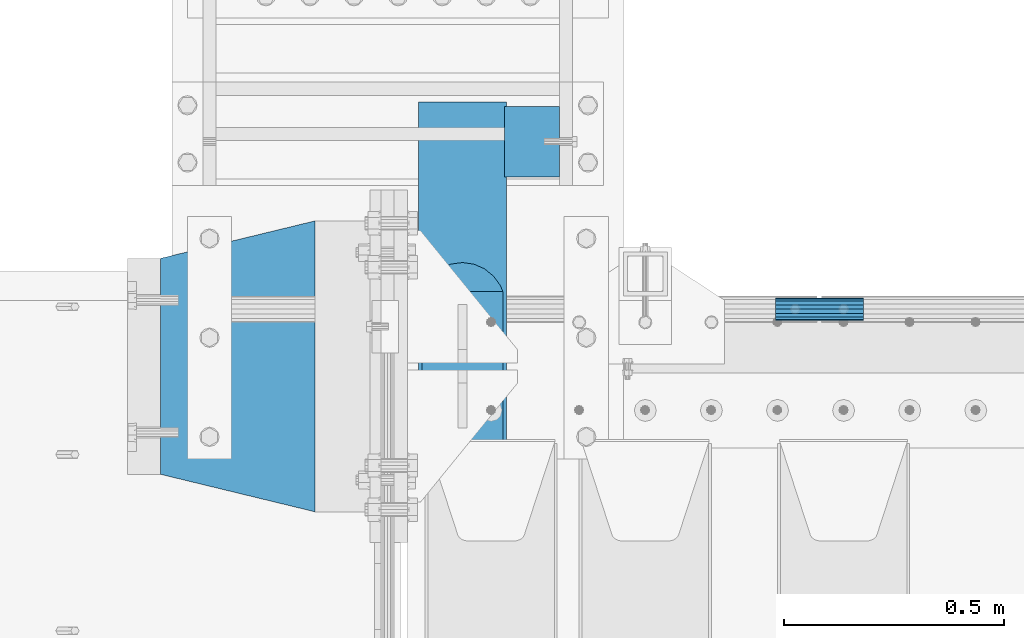
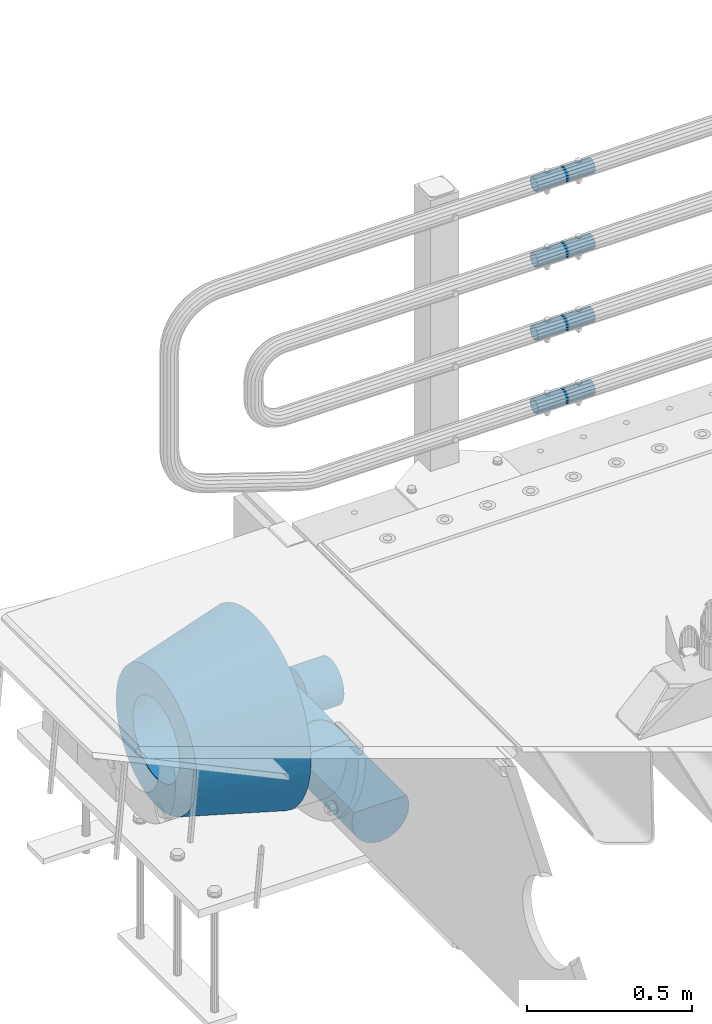
# One storey, part 121 of 208: 7 beams.
"""IFC2X3 building model written with IfcOpenShell, lengths in millimetres."""

import ifcopenshell
import ifcopenshell.guid

model = None  # the IFC model being written
_history = None  # IfcOwnerHistory: only IFC2X3 demands one
_inside = {}  # id of a spatial element -> (the spatial element, [elements in it])
_under = {}  # id of a project, library or spatial element -> (it, [spatial elements below it])
_declared = {}  # id of a project -> (the project, [libraries it declares])
_typed = {}  # id of a type object -> (the type object, [elements of that type])
_made_of = {}  # id of a material, layer set ... -> (it, [elements and type objects made of it])


def new_model(schema):
    """Start an empty IFC model of exactly this schema.

    Asked for "IFC4X3", IfcOpenShell would pick the latest addendum, in which some entities
    have other attributes; the version numbers below select the first issue.
    IFC2X3 requires an IfcOwnerHistory on every rooted entity: one is made here for all.
    """
    global model, _history
    if schema == "IFC4X3":
        model = ifcopenshell.file(schema_version=(4, 3, 0, 0))
    else:
        model = ifcopenshell.file(schema=schema)
    _inside.clear()
    _under.clear()
    _declared.clear()
    _typed.clear()
    _made_of.clear()
    _history = None
    if model.schema == "IFC2X3":
        org = make("IfcOrganization", Name="unknown")
        user = make(
            "IfcPersonAndOrganization",
            ThePerson=make("IfcPerson", FamilyName="unknown"),
            TheOrganization=org,
        )
        app = make(
            "IfcApplication",
            ApplicationDeveloper=org,
            Version="unknown",
            ApplicationFullName="unknown",
            ApplicationIdentifier="unknown",
        )
        _history = make(
            "IfcOwnerHistory",
            OwningUser=user,
            OwningApplication=app,
            ChangeAction="ADDED",
            CreationDate=0,
        )
    return model


def make(cls, **values):
    """One entity of the class cls with the attributes given. An attribute that is None is left unset."""
    return model.create_entity(
        cls, **{name: value for name, value in values.items() if value is not None}
    )


def rooted(cls, **values):
    """An entity with a GlobalId (a new one), such as an element, a storey or a relation."""
    return make(cls, GlobalId=ifcopenshell.guid.new(), OwnerHistory=_history, **values)


def si_unit(unit_type, name, prefix=None):
    """IfcSIUnit, for example si_unit("LENGTHUNIT", "METRE", prefix="MILLI")."""
    return make("IfcSIUnit", UnitType=unit_type, Prefix=prefix, Name=name)


def assignment(units):
    """IfcUnitAssignment: the units of a project."""
    return None if units is None else make("IfcUnitAssignment", Units=units)


def point(xyz):
    """IfcCartesianPoint."""
    return None if xyz is None else make("IfcCartesianPoint", Coordinates=xyz)


def direction(xyz):
    """IfcDirection."""
    return None if xyz is None else make("IfcDirection", DirectionRatios=xyz)


def frame(location, z_axis=None, x_axis=None):
    """IfcAxis2Placement3D, a coordinate frame: its origin and axes. An axis left out is left unset."""
    return make(
        "IfcAxis2Placement3D",
        Location=point(location),
        Axis=direction(z_axis),
        RefDirection=direction(x_axis),
    )


def origin_with_axes():
    """The frame at (0, 0, 0) with the z axis (0, 0, 1) and the x axis (1, 0, 0) written out."""
    return frame((0.0, 0.0, 0.0), z_axis=(0.0, 0.0, 1.0), x_axis=(1.0, 0.0, 0.0))


def place(relative_to, where):
    """IfcLocalPlacement: puts the frame where relative to a parent placement (None: the world)."""
    return make(
        "IfcLocalPlacement", PlacementRelTo=relative_to, RelativePlacement=where
    )


def context(
    kind, dimensions, precision=None, world=None, true_north=None, identifier=None
):
    """IfcGeometricRepresentationContext, for example the 3D "Model" context."""
    return make(
        "IfcGeometricRepresentationContext",
        ContextIdentifier=identifier,
        ContextType=kind,
        CoordinateSpaceDimension=dimensions,
        Precision=precision,
        WorldCoordinateSystem=world,
        TrueNorth=true_north,
    )


def subcontext(parent, identifier, kind, view, scale=None):
    """IfcGeometricRepresentationSubContext, for example "Body" below "Model"."""
    return make(
        "IfcGeometricRepresentationSubContext",
        ContextIdentifier=identifier,
        ContextType=kind,
        ParentContext=parent,
        TargetScale=scale,
        TargetView=view,
    )


def project(units=None, contexts=None):
    """IfcProject with its units and contexts."""
    return rooted(
        "IfcProject",
        Name="project",
        RepresentationContexts=contexts,
        UnitsInContext=assignment(units),
    )


def spatial(cls, under=None, at=None, **own):
    """A site, building, storey or space (cls), placed at a placement, below another one or the project."""
    s = rooted(cls, ObjectPlacement=at, **own)
    if under is not None:
        _under.setdefault(under.id(), (under, []))[1].append(s)
    return s


def faces_of(points, faces, orient=None, outer=None):
    """IfcFace entities. A face is a list of loops; a loop is a list of indices into points, from 0.

    orient and outer hold one flag for each loop. By default every Orientation is true, the
    first loop of a face is its IfcFaceOuterBound and the others are IfcFaceBound.
    """
    made = []
    for i, loops in enumerate(faces):
        bounds = []
        for j, loop in enumerate(loops):
            is_outer = j == 0 if outer is None else outer[i][j]
            bounds.append(
                make(
                    "IfcFaceOuterBound" if is_outer else "IfcFaceBound",
                    Bound=make("IfcPolyLoop", Polygon=[points[k] for k in loop]),
                    Orientation=True if orient is None else orient[i][j],
                )
            )
        made.append(make("IfcFace", Bounds=bounds))
    return made


def faceted_brep(points, faces, orient=None, outer=None, voids=None):
    """IfcFacetedBrep: a solid bounded by flat faces; with voids (closed shells), ...WithVoids."""
    shared = [point(p) for p in points]
    hull = make("IfcClosedShell", CfsFaces=faces_of(shared, faces, orient, outer))
    if voids is None:
        return make("IfcFacetedBrep", Outer=hull)
    return make(
        "IfcFacetedBrepWithVoids",
        Outer=hull,
        Voids=[
            make(cls, CfsFaces=faces_of(shared, fs, o, b)) for cls, fs, o, b in voids
        ],
    )


def shape(context_of_items, identifier, shape_type, items):
    """IfcShapeRepresentation: the items that make up one representation, for example the "Body"."""
    return make(
        "IfcShapeRepresentation",
        ContextOfItems=context_of_items,
        RepresentationIdentifier=identifier,
        RepresentationType=shape_type,
        Items=items,
    )


def material(Name=None, Category=None):
    """IfcMaterial."""
    return make("IfcMaterial", Name=Name, Category=Category)


def made_of(thing, what):
    """Note that an element or type object is made of a material, layer set ...; save() writes the relation."""
    if what is not None:
        _made_of.setdefault(what.id(), (what, []))[1].append(thing)
    return thing


def type_object(cls, material=None, **own):
    """A type object (cls), such as IfcWallType, which elements share."""
    return made_of(rooted(cls, **own), material)


def element(
    cls,
    number,
    at=None,
    inside=None,
    cuts=None,
    type_object=None,
    material=None,
    context=None,
    identifier="Body",
    shape_type=None,
    held_by="IfcProductDefinitionShape",
    body=None,
    shapes=None,
    **own,
):
    """One element of the class cls, such as IfcWall. Its Tag is "e" and its number.

    at: its placement. inside: the storey or other place that contains it. cuts: it is an
    opening in that element (IfcRelVoidsElement). A single representation is given by context,
    identifier, shape_type and body (its items); several are given by shapes. held_by: the class
    of the entity that holds the representations. save() writes the other relations.
    """
    e = rooted(cls, Tag="e%d" % number, ObjectPlacement=at, **own)
    if body is not None:
        shapes = [shape(context, identifier, shape_type, body)]
    if shapes is not None:
        e.Representation = make(held_by, Representations=shapes)
    if inside is not None:
        _inside.setdefault(inside.id(), (inside, []))[1].append(e)
    if cuts is not None:
        rooted(
            "IfcRelVoidsElement", RelatingBuildingElement=cuts, RelatedOpeningElement=e
        )
    if type_object is not None:
        _typed.setdefault(type_object.id(), (type_object, []))[1].append(e)
    return made_of(e, material)


def aggregate(whole, parts):
    """IfcRelAggregates: a whole, such as a stair, and the parts it consists of."""
    return rooted("IfcRelAggregates", RelatingObject=whole, RelatedObjects=parts)


def save(model, path):
    """Write the relations noted so far, then the file.

    IfcRelAggregates (storeys below a building ...), IfcRelContainedInSpatialStructure (elements
    in a storey), IfcRelDefinesByType, IfcRelAssociatesMaterial and IfcRelDeclares: one each for
    every whole, place, type object, material and project.
    """
    for whole, parts in _under.values():
        aggregate(whole, parts)
    for where, things in _inside.values():
        rooted(
            "IfcRelContainedInSpatialStructure",
            RelatedElements=things,
            RelatingStructure=where,
        )
    for kind, things in _typed.values():
        rooted("IfcRelDefinesByType", RelatedObjects=things, RelatingType=kind)
    for what, things in _made_of.values():
        rooted("IfcRelAssociatesMaterial", RelatedObjects=things, RelatingMaterial=what)
    for by, libraries in _declared.values():
        rooted("IfcRelDeclares", RelatingContext=by, RelatedDefinitions=libraries)
    model.write(path)


model = new_model("IFC2X3")

# Units and contexts
model_context = context("Model", 3, precision=1e-05, world=origin_with_axes())
body_context = subcontext(model_context, "Body", "Model", "MODEL_VIEW")
ifc_project = project(units=[si_unit("LENGTHUNIT", "METRE", prefix="MILLI"), si_unit("AREAUNIT", "SQUARE_METRE"), si_unit("VOLUMEUNIT", "CUBIC_METRE"), si_unit("MASSUNIT", "GRAM", prefix="KILO"), si_unit("TIMEUNIT", "SECOND"), si_unit("PLANEANGLEUNIT", "RADIAN"), si_unit("SOLIDANGLEUNIT", "STERADIAN"), si_unit("THERMODYNAMICTEMPERATUREUNIT", "DEGREE_CELSIUS"), si_unit("LUMINOUSINTENSITYUNIT", "LUMEN")], contexts=[model_context])

# Site, building, storey
site_placement = place(None, origin_with_axes())
site = spatial("IfcSite", under=ifc_project, at=site_placement, CompositionType="ELEMENT")
building_placement = place(site_placement, origin_with_axes())
building = spatial("IfcBuilding", under=site, at=building_placement, Name="Standard", CompositionType="ELEMENT")
storey_placement = place(building_placement, origin_with_axes())
storey = spatial("IfcBuildingStorey", under=building, at=storey_placement, Name="Undefined", CompositionType="ELEMENT", Elevation=0.0)

# Beams
ifc_material_1 = material(Name="STEEL/S355N")
beam_type_1 = type_object("IfcBeamType", Name="D200", PredefinedType="NOTDEFINED")
beam_1_placement = place(storey_placement, frame((-42315.0, 6600.0, -928.0), z_axis=(0.0, 0.0, 1.0), x_axis=(0.0, -1.0, 0.0)))
element("IfcBeam", 1, at=beam_1_placement, inside=storey, type_object=beam_type_1, material=ifc_material_1, ObjectType="D200", context=body_context, shape_type="Brep", body=[
    faceted_brep([(430.0, 91.573103126917, 38.0), (430.0, -91.5731031269243, 38.0), (770.0, -91.5731031269243, 37.9999999999994), (770.0, 91.5731031269243, 37.9999999999994), (417.294117647059, 86.6025403784442, 50.0), (395.365164344953, 70.7106781186521, 70.7106781186548), (378.538486658119, 50.0, 86.6025403784439), (367.96079486351, 25.88190451025, 96.5925826289068), (364.35294117647, 0.0, 100.0), (367.96079486351, -25.88190451025, 96.5925826289068), (378.538486658119, -50.0, 86.6025403784439), (395.365164344953, -70.7106781186521, 70.7106781186548), (417.294117647059, -86.6025403784442, 50.0), (0.0, -96.5925826289094, 25.8819045102521), (0.0, -100.0, 0.0), (770.0, -100.0, 0.0), (770.0, -96.5925826289094, 25.8819045102521), (0.0, 96.5925826289094, -25.8819045102521), (0.0, 100.0, 0.0), (770.0, 100.0, 0.0), (770.0, 96.5925826289094, -25.8819045102521), (0.0, 86.6025403784442, -50.0), (770.0, 86.6025403784442, -50.0), (0.0, 70.7106781186521, -70.7106781186548), (770.0, 70.7106781186521, -70.7106781186548), (0.0, 50.0, -86.6025403784438), (770.0, 50.0, -86.6025403784438), (0.0, 25.88190451025, -96.5925826289067), (770.0, 25.88190451025, -96.5925826289067), (0.0, 0.0, -100.0), (770.0, 0.0, -100.0), (0.0, -25.88190451025, -96.5925826289069), (770.0, -25.88190451025, -96.5925826289069), (0.0, -50.0, -86.6025403784439), (770.0, -50.0, -86.6025403784439), (0.0, -70.7106781186521, -70.7106781186548), (770.0, -70.7106781186521, -70.7106781186548), (0.0, -86.6025403784442, -50.0), (770.0, -86.6025403784442, -50.0), (0.0, -96.5925826289094, -25.8819045102522), (770.0, -96.5925826289094, -25.8819045102522), (0.0, -86.6025403784442, 50.0), (0.0, -70.7106781186521, 70.7106781186548), (0.0, -50.0, 86.6025403784439), (0.0, -25.88190451025, 96.5925826289068), (0.0, 0.0, 100.0), (0.0, 25.88190451025, 96.5925826289068), (0.0, 50.0, 86.6025403784439), (0.0, 70.7106781186521, 70.7106781186548), (0.0, 86.6025403784442, 50.0), (0.0, 96.5925826289094, 25.8819045102521), (770.0, 96.5925826289094, 25.8819045102521)], [[[0, 1, 2, 3]], [[4, 5, 6, 7, 8, 9, 10, 11, 12, 1, 0]], [[13, 14, 15, 16]], [[17, 18, 19, 20]], [[21, 17, 20, 22]], [[23, 21, 22, 24]], [[25, 23, 24, 26]], [[27, 25, 26, 28]], [[29, 27, 28, 30]], [[31, 29, 30, 32]], [[33, 31, 32, 34]], [[35, 33, 34, 36]], [[37, 35, 36, 38]], [[39, 37, 38, 40]], [[14, 39, 40, 15]], [[13, 41, 42, 43, 44, 45, 46, 47, 48, 49, 50, 18, 17, 21, 23, 25, 27, 29, 31, 33, 35, 37, 39, 14]], [[18, 50, 51, 19]], [[16, 15, 40, 38, 36, 34, 32, 30, 28, 26, 24, 22, 20, 19, 51, 3, 2]], [[41, 13, 16, 2, 1, 12]], [[42, 41, 12, 11]], [[43, 42, 11, 10]], [[44, 43, 10, 9]], [[45, 44, 9, 8]], [[46, 45, 8, 7]], [[47, 46, 7, 6]], [[48, 47, 6, 5]], [[49, 48, 5, 4]], [[51, 50, 49, 4, 0, 3]]]),
])
ifc_material_2 = material()
beam_type_2 = type_object("IfcBeamType", PredefinedType="NOTDEFINED")
beam_2_placement = place(storey_placement, frame((-42220.0000000006, 6509.99999999966, -923.000000000004), z_axis=(0.0, 0.0, 1.0), x_axis=(1.0, 0.0, 0.0)))
element("IfcBeam", 2, at=beam_2_placement, inside=storey, type_object=beam_type_2, material=ifc_material_2, context=body_context, shape_type="Brep", body=[
    faceted_brep([(0.0, -80.0, 0.0), (0.0, -77.2740661031254, -20.7055236082017), (125.0, -77.2740661031254, -20.7055236082017), (125.0, -80.0, 0.0), (0.0, -69.2820323027551, -40.0), (125.0, -69.2820323027551, -40.0), (0.0, -56.5685424949238, -56.5685424949238), (125.0, -56.5685424949238, -56.5685424949238), (0.0, -39.9999999999999, -69.2820323027552), (125.0, -39.9999999999999, -69.2820323027552), (0.0, -20.7055236082016, -77.2740661031255), (125.0, -20.7055236082016, -77.2740661031255), (0.0, 0.0, -80.0), (125.0, 0.0, -80.0), (0.0, 20.7055236082017, -77.2740661031255), (125.0, 20.7055236082017, -77.2740661031255), (0.0, 40.0, -69.2820323027551), (125.0, 40.0, -69.2820323027551), (0.0, 56.5685424949238, -56.5685424949238), (125.0, 56.5685424949238, -56.5685424949238), (0.0, 69.2820323027552, -40.0), (125.0, 69.2820323027552, -40.0), (0.0, 77.2740661031255, -20.7055236082016), (125.0, 77.2740661031255, -20.7055236082016), (0.0, 80.0, 0.0), (125.0, 80.0, 0.0), (0.0, 77.2740661031255, 20.7055236082017), (125.0, 77.2740661031255, 20.7055236082017), (0.0, 69.2820323027551, 40.0), (125.0, 69.2820323027551, 40.0), (0.0, 56.5685424949238, 56.5685424949238), (125.0, 56.5685424949238, 56.5685424949238), (0.0, 40.0, 69.2820323027551), (125.0, 40.0, 69.2820323027551), (0.0, 20.7055236082017, 77.2740661031255), (125.0, 20.7055236082017, 77.2740661031255), (0.0, 0.0, 80.0), (125.0, 0.0, 80.0), (0.0, -20.7055236082017, 77.2740661031255), (125.0, -20.7055236082017, 77.2740661031255), (0.0, -40.0, 69.2820323027551), (125.0, -40.0, 69.2820323027551), (0.0, -56.5685424949238, 56.5685424949238), (125.0, -56.5685424949238, 56.5685424949238), (0.0, -69.2820323027551, 40.0), (125.0, -69.2820323027551, 40.0), (0.0, -77.2740661031254, 20.7055236082017), (125.0, -77.2740661031254, 20.7055236082017)], [[[0, 1, 2, 3]], [[1, 4, 5, 2]], [[4, 6, 7, 5]], [[6, 8, 9, 7]], [[8, 10, 11, 9]], [[10, 12, 13, 11]], [[12, 14, 15, 13]], [[14, 16, 17, 15]], [[16, 18, 19, 17]], [[18, 20, 21, 19]], [[20, 22, 23, 21]], [[22, 24, 25, 23]], [[24, 26, 27, 25]], [[26, 28, 29, 27]], [[28, 30, 31, 29]], [[30, 32, 33, 31]], [[32, 34, 35, 33]], [[34, 36, 37, 35]], [[36, 38, 39, 37]], [[38, 40, 41, 39]], [[40, 42, 43, 41]], [[42, 44, 45, 43]], [[44, 46, 47, 45]], [[46, 0, 3, 47]], [[5, 7, 9, 11, 13, 15, 17, 19, 21, 23, 25, 27, 29, 31, 33, 35, 37, 39, 41, 43, 45, 47, 3, 2]], [[46, 44, 42, 40, 38, 36, 34, 32, 30, 28, 26, 24, 22, 20, 18, 16, 14, 12, 10, 8, 6, 4, 1, 0]]]),
])
ifc_material_3 = material()
beam_type_3 = type_object("IfcBeamType", PredefinedType="NOTDEFINED")
beam_3_placement = place(storey_placement, frame((-41605.0024970001, 6129.8500000004, 149.849999999725), z_axis=(0.0, 0.0, 1.0), x_axis=(1.0, 0.0, 0.0)))
element("IfcBeam", 3, at=beam_3_placement, inside=storey, type_object=beam_type_3, material=ifc_material_3, context=body_context, shape_type="Brep", body=[
    faceted_brep([(0.0, -21.8999999999996, 0.0), (0.0, -20.2329617619971, 8.38076716879547), (200.0, -20.2329617619971, 8.38076716879547), (200.0, -21.8999999999996, 0.0), (0.0, -15.4856385079856, 15.4856385079854), (200.0, -15.4856385079856, 15.4856385079854), (0.0, -8.3807671687955, 20.2329617619972), (200.0, -8.3807671687955, 20.2329617619972), (0.0, 0.0, 21.9), (200.0, 0.0, 21.9), (0.0, 8.3807671687955, 20.2329617619972), (200.0, 8.3807671687955, 20.2329617619972), (0.0, 15.4856385079856, 15.4856385079854), (200.0, 15.4856385079856, 15.4856385079854), (0.0, 20.2329617619971, 8.38076716879547), (200.0, 20.2329617619971, 8.38076716879547), (0.0, 21.8999999999996, 0.0), (200.0, 21.8999999999996, 0.0), (0.0, 20.2329617619971, -8.38076716879547), (200.0, 20.2329617619971, -8.38076716879547), (0.0, 15.4856385079856, -15.4856385079854), (200.0, 15.4856385079856, -15.4856385079854), (0.0, 8.3807671687955, -20.2329617619972), (200.0, 8.3807671687955, -20.2329617619972), (0.0, 0.0, -21.9), (200.0, 0.0, -21.9), (0.0, -8.3807671687955, -20.2329617619972), (200.0, -8.3807671687955, -20.2329617619972), (0.0, -15.4856385079856, -15.4856385079854), (200.0, -15.4856385079856, -15.4856385079854), (0.0, -20.2329617619971, -8.38076716879547), (200.0, -20.2329617619971, -8.38076716879547), (0.0, -25.5, 0.0), (0.0, -23.5589280790382, -9.7584275253098), (200.0, -23.5589280790382, -9.7584275253098), (200.0, -25.5, 0.0), (0.0, -18.0312229202573, -18.031222920257), (200.0, -18.0312229202573, -18.031222920257), (0.0, -9.75842752530934, -23.5589280790378), (200.0, -9.75842752530934, -23.5589280790378), (0.0, 0.0, -25.5), (200.0, 0.0, -25.5), (0.0, 9.75842752531025, -23.5589280790378), (200.0, 9.75842752531025, -23.5589280790378), (0.0, 18.0312229202573, -18.031222920257), (200.0, 18.0312229202573, -18.031222920257), (0.0, 23.5589280790382, -9.7584275253098), (200.0, 23.5589280790382, -9.7584275253098), (0.0, 25.5, 0.0), (200.0, 25.5, 0.0), (0.0, 23.5589280790382, 9.7584275253098), (200.0, 23.5589280790382, 9.7584275253098), (0.0, 18.0312229202573, 18.031222920257), (200.0, 18.0312229202573, 18.031222920257), (0.0, 9.75842752530934, 23.5589280790378), (200.0, 9.75842752530934, 23.5589280790378), (0.0, 0.0, 25.5), (200.0, 0.0, 25.5), (0.0, -9.75842752530934, 23.5589280790378), (200.0, -9.75842752530934, 23.5589280790378), (0.0, -18.0312229202573, 18.031222920257), (200.0, -18.0312229202573, 18.031222920257), (0.0, -23.5589280790382, 9.7584275253098), (200.0, -23.5589280790382, 9.7584275253098)], [[[0, 1, 2, 3]], [[1, 4, 5, 2]], [[4, 6, 7, 5]], [[6, 8, 9, 7]], [[8, 10, 11, 9]], [[10, 12, 13, 11]], [[12, 14, 15, 13]], [[14, 16, 17, 15]], [[16, 18, 19, 17]], [[18, 20, 21, 19]], [[20, 22, 23, 21]], [[22, 24, 25, 23]], [[24, 26, 27, 25]], [[26, 28, 29, 27]], [[28, 30, 31, 29]], [[30, 0, 3, 31]], [[32, 33, 34, 35]], [[33, 36, 37, 34]], [[36, 38, 39, 37]], [[38, 40, 41, 39]], [[40, 42, 43, 41]], [[42, 44, 45, 43]], [[44, 46, 47, 45]], [[46, 48, 49, 47]], [[48, 50, 51, 49]], [[50, 52, 53, 51]], [[52, 54, 55, 53]], [[54, 56, 57, 55]], [[56, 58, 59, 57]], [[58, 60, 61, 59]], [[60, 62, 63, 61]], [[62, 32, 35, 63]], [[37, 39, 41, 43, 45, 47, 49, 51, 53, 55, 57, 59, 61, 63, 35, 34], [5, 7, 9, 11, 13, 15, 17, 19, 21, 23, 25, 27, 29, 31, 3, 2]], [[62, 60, 58, 56, 54, 52, 50, 48, 46, 44, 42, 40, 38, 36, 33, 32], [30, 28, 26, 24, 22, 20, 18, 16, 14, 12, 10, 8, 6, 4, 1, 0]]]),
])
beam_4_placement = place(storey_placement, frame((-41605.0024970001, 6129.8500000004, 420.149999999724), z_axis=(0.0, 0.0, 1.0), x_axis=(1.0, 0.0, 0.0)))
element("IfcBeam", 4, at=beam_4_placement, inside=storey, type_object=beam_type_3, material=ifc_material_3, context=body_context, shape_type="Brep", body=[
    faceted_brep([(0.0, -21.8999999999996, 0.0), (0.0, -20.2329617619971, 8.38076716879547), (200.0, -20.2329617619971, 8.38076716879547), (200.0, -21.8999999999996, 0.0), (0.0, -15.4856385079856, 15.4856385079854), (200.0, -15.4856385079856, 15.4856385079854), (0.0, -8.3807671687955, 20.2329617619972), (200.0, -8.3807671687955, 20.2329617619972), (0.0, 0.0, 21.9), (200.0, 0.0, 21.9), (0.0, 8.3807671687955, 20.2329617619972), (200.0, 8.3807671687955, 20.2329617619972), (0.0, 15.4856385079856, 15.4856385079854), (200.0, 15.4856385079856, 15.4856385079854), (0.0, 20.2329617619971, 8.38076716879547), (200.0, 20.2329617619971, 8.38076716879547), (0.0, 21.8999999999996, 0.0), (200.0, 21.8999999999996, 0.0), (0.0, 20.2329617619971, -8.38076716879547), (200.0, 20.2329617619971, -8.38076716879547), (0.0, 15.4856385079856, -15.4856385079854), (200.0, 15.4856385079856, -15.4856385079854), (0.0, 8.3807671687955, -20.2329617619972), (200.0, 8.3807671687955, -20.2329617619972), (0.0, 0.0, -21.9), (200.0, 0.0, -21.9), (0.0, -8.3807671687955, -20.2329617619972), (200.0, -8.3807671687955, -20.2329617619972), (0.0, -15.4856385079856, -15.4856385079854), (200.0, -15.4856385079856, -15.4856385079854), (0.0, -20.2329617619971, -8.38076716879547), (200.0, -20.2329617619971, -8.38076716879547), (0.0, -25.5, 0.0), (0.0, -23.5589280790382, -9.7584275253098), (200.0, -23.5589280790382, -9.7584275253098), (200.0, -25.5, 0.0), (0.0, -18.0312229202573, -18.031222920257), (200.0, -18.0312229202573, -18.031222920257), (0.0, -9.75842752530934, -23.5589280790378), (200.0, -9.75842752530934, -23.5589280790378), (0.0, 0.0, -25.5), (200.0, 0.0, -25.5), (0.0, 9.75842752531025, -23.5589280790378), (200.0, 9.75842752531025, -23.5589280790378), (0.0, 18.0312229202573, -18.031222920257), (200.0, 18.0312229202573, -18.031222920257), (0.0, 23.5589280790382, -9.7584275253098), (200.0, 23.5589280790382, -9.7584275253098), (0.0, 25.5, 0.0), (200.0, 25.5, 0.0), (0.0, 23.5589280790382, 9.7584275253098), (200.0, 23.5589280790382, 9.7584275253098), (0.0, 18.0312229202573, 18.031222920257), (200.0, 18.0312229202573, 18.031222920257), (0.0, 9.75842752530934, 23.5589280790378), (200.0, 9.75842752530934, 23.5589280790378), (0.0, 0.0, 25.5), (200.0, 0.0, 25.5), (0.0, -9.75842752530934, 23.5589280790378), (200.0, -9.75842752530934, 23.5589280790378), (0.0, -18.0312229202573, 18.031222920257), (200.0, -18.0312229202573, 18.031222920257), (0.0, -23.5589280790382, 9.7584275253098), (200.0, -23.5589280790382, 9.7584275253098)], [[[0, 1, 2, 3]], [[1, 4, 5, 2]], [[4, 6, 7, 5]], [[6, 8, 9, 7]], [[8, 10, 11, 9]], [[10, 12, 13, 11]], [[12, 14, 15, 13]], [[14, 16, 17, 15]], [[16, 18, 19, 17]], [[18, 20, 21, 19]], [[20, 22, 23, 21]], [[22, 24, 25, 23]], [[24, 26, 27, 25]], [[26, 28, 29, 27]], [[28, 30, 31, 29]], [[30, 0, 3, 31]], [[32, 33, 34, 35]], [[33, 36, 37, 34]], [[36, 38, 39, 37]], [[38, 40, 41, 39]], [[40, 42, 43, 41]], [[42, 44, 45, 43]], [[44, 46, 47, 45]], [[46, 48, 49, 47]], [[48, 50, 51, 49]], [[50, 52, 53, 51]], [[52, 54, 55, 53]], [[54, 56, 57, 55]], [[56, 58, 59, 57]], [[58, 60, 61, 59]], [[60, 62, 63, 61]], [[62, 32, 35, 63]], [[37, 39, 41, 43, 45, 47, 49, 51, 53, 55, 57, 59, 61, 63, 35, 34], [5, 7, 9, 11, 13, 15, 17, 19, 21, 23, 25, 27, 29, 31, 3, 2]], [[62, 60, 58, 56, 54, 52, 50, 48, 46, 44, 42, 40, 38, 36, 33, 32], [30, 28, 26, 24, 22, 20, 18, 16, 14, 12, 10, 8, 6, 4, 1, 0]]]),
])
beam_5_placement = place(storey_placement, frame((-41605.0024970001, 6129.8500000004, 969.849999999725), z_axis=(0.0, 0.0, 1.0), x_axis=(1.0, 0.0, 0.0)))
element("IfcBeam", 5, at=beam_5_placement, inside=storey, type_object=beam_type_3, material=ifc_material_3, context=body_context, shape_type="Brep", body=[
    faceted_brep([(0.0, -21.8999999999996, 0.0), (0.0, -20.2329617619971, 8.38076716879547), (200.0, -20.2329617619971, 8.38076716879547), (200.0, -21.8999999999996, 0.0), (0.0, -15.4856385079856, 15.4856385079854), (200.0, -15.4856385079856, 15.4856385079854), (0.0, -8.3807671687955, 20.2329617619972), (200.0, -8.3807671687955, 20.2329617619972), (0.0, 0.0, 21.9), (200.0, 0.0, 21.9), (0.0, 8.3807671687955, 20.2329617619972), (200.0, 8.3807671687955, 20.2329617619972), (0.0, 15.4856385079856, 15.4856385079854), (200.0, 15.4856385079856, 15.4856385079854), (0.0, 20.2329617619971, 8.38076716879547), (200.0, 20.2329617619971, 8.38076716879547), (0.0, 21.8999999999996, 0.0), (200.0, 21.8999999999996, 0.0), (0.0, 20.2329617619971, -8.38076716879547), (200.0, 20.2329617619971, -8.38076716879547), (0.0, 15.4856385079856, -15.4856385079854), (200.0, 15.4856385079856, -15.4856385079854), (0.0, 8.3807671687955, -20.2329617619972), (200.0, 8.3807671687955, -20.2329617619972), (0.0, 0.0, -21.9), (200.0, 0.0, -21.9), (0.0, -8.3807671687955, -20.2329617619972), (200.0, -8.3807671687955, -20.2329617619972), (0.0, -15.4856385079856, -15.4856385079854), (200.0, -15.4856385079856, -15.4856385079854), (0.0, -20.2329617619971, -8.38076716879547), (200.0, -20.2329617619971, -8.38076716879547), (0.0, -25.5, 0.0), (0.0, -23.5589280790382, -9.7584275253098), (200.0, -23.5589280790382, -9.7584275253098), (200.0, -25.5, 0.0), (0.0, -18.0312229202573, -18.031222920257), (200.0, -18.0312229202573, -18.031222920257), (0.0, -9.75842752530934, -23.5589280790378), (200.0, -9.75842752530934, -23.5589280790378), (0.0, 0.0, -25.5), (200.0, 0.0, -25.5), (0.0, 9.75842752531025, -23.5589280790378), (200.0, 9.75842752531025, -23.5589280790378), (0.0, 18.0312229202573, -18.031222920257), (200.0, 18.0312229202573, -18.031222920257), (0.0, 23.5589280790382, -9.7584275253098), (200.0, 23.5589280790382, -9.7584275253098), (0.0, 25.5, 0.0), (200.0, 25.5, 0.0), (0.0, 23.5589280790382, 9.7584275253098), (200.0, 23.5589280790382, 9.7584275253098), (0.0, 18.0312229202573, 18.031222920257), (200.0, 18.0312229202573, 18.031222920257), (0.0, 9.75842752530934, 23.5589280790378), (200.0, 9.75842752530934, 23.5589280790378), (0.0, 0.0, 25.5), (200.0, 0.0, 25.5), (0.0, -9.75842752530934, 23.5589280790378), (200.0, -9.75842752530934, 23.5589280790378), (0.0, -18.0312229202573, 18.031222920257), (200.0, -18.0312229202573, 18.031222920257), (0.0, -23.5589280790382, 9.7584275253098), (200.0, -23.5589280790382, 9.7584275253098)], [[[0, 1, 2, 3]], [[1, 4, 5, 2]], [[4, 6, 7, 5]], [[6, 8, 9, 7]], [[8, 10, 11, 9]], [[10, 12, 13, 11]], [[12, 14, 15, 13]], [[14, 16, 17, 15]], [[16, 18, 19, 17]], [[18, 20, 21, 19]], [[20, 22, 23, 21]], [[22, 24, 25, 23]], [[24, 26, 27, 25]], [[26, 28, 29, 27]], [[28, 30, 31, 29]], [[30, 0, 3, 31]], [[32, 33, 34, 35]], [[33, 36, 37, 34]], [[36, 38, 39, 37]], [[38, 40, 41, 39]], [[40, 42, 43, 41]], [[42, 44, 45, 43]], [[44, 46, 47, 45]], [[46, 48, 49, 47]], [[48, 50, 51, 49]], [[50, 52, 53, 51]], [[52, 54, 55, 53]], [[54, 56, 57, 55]], [[56, 58, 59, 57]], [[58, 60, 61, 59]], [[60, 62, 63, 61]], [[62, 32, 35, 63]], [[37, 39, 41, 43, 45, 47, 49, 51, 53, 55, 57, 59, 61, 63, 35, 34], [5, 7, 9, 11, 13, 15, 17, 19, 21, 23, 25, 27, 29, 31, 3, 2]], [[62, 60, 58, 56, 54, 52, 50, 48, 46, 44, 42, 40, 38, 36, 33, 32], [30, 28, 26, 24, 22, 20, 18, 16, 14, 12, 10, 8, 6, 4, 1, 0]]]),
])
beam_6_placement = place(storey_placement, frame((-41605.0024970001, 6129.8500000004, 689.849999999725), z_axis=(0.0, 0.0, 1.0), x_axis=(1.0, 0.0, 0.0)))
element("IfcBeam", 6, at=beam_6_placement, inside=storey, type_object=beam_type_3, material=ifc_material_3, context=body_context, shape_type="Brep", body=[
    faceted_brep([(0.0, -21.8999999999996, 0.0), (0.0, -20.2329617619971, 8.38076716879547), (200.0, -20.2329617619971, 8.38076716879547), (200.0, -21.8999999999996, 0.0), (0.0, -15.4856385079856, 15.4856385079854), (200.0, -15.4856385079856, 15.4856385079854), (0.0, -8.3807671687955, 20.2329617619972), (200.0, -8.3807671687955, 20.2329617619972), (0.0, 0.0, 21.9), (200.0, 0.0, 21.9), (0.0, 8.3807671687955, 20.2329617619972), (200.0, 8.3807671687955, 20.2329617619972), (0.0, 15.4856385079856, 15.4856385079854), (200.0, 15.4856385079856, 15.4856385079854), (0.0, 20.2329617619971, 8.38076716879547), (200.0, 20.2329617619971, 8.38076716879547), (0.0, 21.8999999999996, 0.0), (200.0, 21.8999999999996, 0.0), (0.0, 20.2329617619971, -8.38076716879547), (200.0, 20.2329617619971, -8.38076716879547), (0.0, 15.4856385079856, -15.4856385079854), (200.0, 15.4856385079856, -15.4856385079854), (0.0, 8.3807671687955, -20.2329617619972), (200.0, 8.3807671687955, -20.2329617619972), (0.0, 0.0, -21.9), (200.0, 0.0, -21.9), (0.0, -8.3807671687955, -20.2329617619972), (200.0, -8.3807671687955, -20.2329617619972), (0.0, -15.4856385079856, -15.4856385079854), (200.0, -15.4856385079856, -15.4856385079854), (0.0, -20.2329617619971, -8.38076716879547), (200.0, -20.2329617619971, -8.38076716879547), (0.0, -25.5, 0.0), (0.0, -23.5589280790382, -9.7584275253098), (200.0, -23.5589280790382, -9.7584275253098), (200.0, -25.5, 0.0), (0.0, -18.0312229202573, -18.031222920257), (200.0, -18.0312229202573, -18.031222920257), (0.0, -9.75842752530934, -23.5589280790378), (200.0, -9.75842752530934, -23.5589280790378), (0.0, 0.0, -25.5), (200.0, 0.0, -25.5), (0.0, 9.75842752531025, -23.5589280790378), (200.0, 9.75842752531025, -23.5589280790378), (0.0, 18.0312229202573, -18.031222920257), (200.0, 18.0312229202573, -18.031222920257), (0.0, 23.5589280790382, -9.7584275253098), (200.0, 23.5589280790382, -9.7584275253098), (0.0, 25.5, 0.0), (200.0, 25.5, 0.0), (0.0, 23.5589280790382, 9.7584275253098), (200.0, 23.5589280790382, 9.7584275253098), (0.0, 18.0312229202573, 18.031222920257), (200.0, 18.0312229202573, 18.031222920257), (0.0, 9.75842752530934, 23.5589280790378), (200.0, 9.75842752530934, 23.5589280790378), (0.0, 0.0, 25.5), (200.0, 0.0, 25.5), (0.0, -9.75842752530934, 23.5589280790378), (200.0, -9.75842752530934, 23.5589280790378), (0.0, -18.0312229202573, 18.031222920257), (200.0, -18.0312229202573, 18.031222920257), (0.0, -23.5589280790382, 9.7584275253098), (200.0, -23.5589280790382, 9.7584275253098)], [[[0, 1, 2, 3]], [[1, 4, 5, 2]], [[4, 6, 7, 5]], [[6, 8, 9, 7]], [[8, 10, 11, 9]], [[10, 12, 13, 11]], [[12, 14, 15, 13]], [[14, 16, 17, 15]], [[16, 18, 19, 17]], [[18, 20, 21, 19]], [[20, 22, 23, 21]], [[22, 24, 25, 23]], [[24, 26, 27, 25]], [[26, 28, 29, 27]], [[28, 30, 31, 29]], [[30, 0, 3, 31]], [[32, 33, 34, 35]], [[33, 36, 37, 34]], [[36, 38, 39, 37]], [[38, 40, 41, 39]], [[40, 42, 43, 41]], [[42, 44, 45, 43]], [[44, 46, 47, 45]], [[46, 48, 49, 47]], [[48, 50, 51, 49]], [[50, 52, 53, 51]], [[52, 54, 55, 53]], [[54, 56, 57, 55]], [[56, 58, 59, 57]], [[58, 60, 61, 59]], [[60, 62, 63, 61]], [[62, 32, 35, 63]], [[37, 39, 41, 43, 45, 47, 49, 51, 53, 55, 57, 59, 61, 63, 35, 34], [5, 7, 9, 11, 13, 15, 17, 19, 21, 23, 25, 27, 29, 31, 3, 2]], [[62, 60, 58, 56, 54, 52, 50, 48, 46, 44, 42, 40, 38, 36, 33, 32], [30, 28, 26, 24, 22, 20, 18, 16, 14, 12, 10, 8, 6, 4, 1, 0]]]),
])
ifc_material_4 = material(Name="SCN-500-E2")
beam_type_4 = type_object("IfcBeamType", PredefinedType="NOTDEFINED")
beam_7_placement = place(storey_placement, frame((-42650.0, 6000.0, -515.0), z_axis=(0.0, 0.0, 1.0), x_axis=(-1.0, 0.0, 0.0)))
element("IfcBeam", 7, at=beam_7_placement, inside=storey, type_object=beam_type_4, material=ifc_material_4, context=body_context, shape_type="Brep", body=[
    faceted_brep([(0.0, -330.0, 0.0), (0.0, -326.641075820708, -46.9638966301842), (350.0, -242.506253260828, -34.8671353769549), (350.0, -245.0, 0.0), (0.0, -316.632681292784, -92.9717437576718), (350.0, -235.075778535552, -69.0244764261503), (0.0, -300.178558466991, -137.086954290623), (350.0, -222.859838861857, -101.776678185462), (0.0, -277.613665834289, -178.411469760347), (350.0, -206.107115543639, -132.457000276621), (0.0, -249.397359536905, -216.104042201944), (350.0, -185.158645716793, -160.440879816595), (0.0, -216.104042201944, -249.397359536905), (350.0, -160.440879816595, -185.158645716793), (0.0, -178.411469760347, -277.61366583429), (350.0, -132.457000276621, -206.107115543639), (0.0, -137.086954290622, -300.178558466991), (350.0, -101.776678185463, -222.859838861857), (0.0, -92.9717437576719, -316.632681292784), (350.0, -69.0244764261506, -235.075778535552), (0.0, -46.9638966301836, -326.641075820708), (350.0, -34.867135376955, -242.506253260829), (0.0, 0.0, -330.0), (350.0, 0.0, -245.0), (0.0, 46.9638966301845, -326.641075820708), (350.0, 34.867135376955, -242.506253260829), (0.0, 92.9717437576719, -316.632681292784), (350.0, 69.0244764261506, -235.075778535552), (0.0, 137.086954290622, -300.178558466991), (350.0, 101.776678185463, -222.859838861857), (0.0, 178.411469760347, -277.61366583429), (350.0, 132.457000276621, -206.107115543639), (0.0, 216.104042201944, -249.397359536905), (350.0, 160.440879816595, -185.158645716793), (0.0, 249.397359536905, -216.104042201944), (350.0, 185.158645716793, -160.440879816595), (0.0, 277.613665834289, -178.411469760347), (350.0, 206.107115543639, -132.457000276621), (0.0, 300.178558466991, -137.086954290623), (350.0, 222.859838861857, -101.776678185462), (0.0, 316.632681292785, -92.9717437576717), (350.0, 235.075778535552, -69.0244764261502), (0.0, 326.641075820708, -46.9638966301841), (350.0, 242.506253260828, -34.8671353769548), (0.0, 330.0, 0.0), (350.0, 245.0, 0.0), (0.0, 326.641075820708, 46.9638966301841), (350.0, 242.506253260828, 34.8671353769549), (0.0, 316.632681292784, 92.9717437576718), (350.0, 235.075778535552, 69.0244764261503), (0.0, 300.178558466991, 137.086954290622), (350.0, 222.859838861857, 101.776678185462), (0.0, 277.613665834289, 178.411469760347), (350.0, 206.107115543639, 132.457000276621), (0.0, 249.397359536905, 216.104042201944), (350.0, 185.158645716793, 160.440879816595), (0.0, 216.104042201944, 249.397359536905), (350.0, 160.440879816595, 185.158645716793), (0.0, 178.411469760347, 277.61366583429), (350.0, 132.457000276621, 206.107115543639), (0.0, 137.086954290622, 300.178558466991), (350.0, 101.776678185463, 222.859838861857), (0.0, 92.9717437576719, 316.632681292784), (350.0, 69.0244764261506, 235.075778535552), (0.0, 46.9638966301836, 326.641075820708), (350.0, 34.867135376955, 242.506253260829), (0.0, 0.0, 330.0), (350.0, 0.0, 245.0), (0.0, -46.9638966301845, 326.641075820708), (350.0, -34.867135376955, 242.506253260829), (0.0, -92.9717437576719, 316.632681292784), (350.0, -69.0244764261506, 235.075778535552), (0.0, -137.086954290622, 300.178558466991), (350.0, -101.776678185463, 222.859838861857), (0.0, -178.411469760347, 277.61366583429), (350.0, -132.457000276621, 206.107115543639), (0.0, -216.104042201944, 249.397359536905), (350.0, -160.440879816595, 185.158645716793), (0.0, -249.397359536905, 216.104042201944), (350.0, -185.158645716793, 160.440879816595), (0.0, -277.613665834289, 178.411469760347), (350.0, -206.107115543639, 132.457000276621), (0.0, -300.178558466991, 137.086954290623), (350.0, -222.859838861857, 101.776678185462), (0.0, -316.632681292784, 92.9717437576718), (350.0, -235.075778535552, 69.0244764261503), (0.0, -326.641075820708, 46.9638966301841), (350.0, -242.506253260828, 34.8671353769549), (0.0, -227.093265923131, 0.0), (0.0, -224.781783917484, 32.3187414128026), (350.0, -140.646961357605, 20.2219801595734), (350.0, -142.093265923131, 0.0), (0.0, -217.894393008413, 63.9795664499945), (350.0, -136.337490251181, 40.032299118473), (0.0, -206.571300613232, 94.3379520160985), (350.0, -129.252581008098, 59.0276759109381), (0.0, -191.043012240005, 122.775888927343), (350.0, -119.536461949355, 76.8214194436173), (0.0, -171.625639060125, 148.714462796454), (350.0, -107.386925240013, 93.0513004111044), (0.0, -148.714462796454, 171.625639060125), (350.0, -93.0513004111044, 107.386925240013), (0.0, -122.775888927343, 191.043012240005), (350.0, -76.8214194436177, 119.536461949355), (0.0, -94.3379520160988, 206.571300613232), (350.0, -59.0276759109383, 129.252581008098), (0.0, -63.9795664499943, 217.894393008413), (350.0, -40.032299118473, 136.337490251181), (0.0, -32.3187414128024, 224.781783917484), (350.0, -20.2219801595729, 140.646961357605), (0.0, 0.0, 227.093265923131), (350.0, 0.0, 142.093265923131), (0.0, 32.3187414128024, 224.781783917484), (350.0, 20.2219801595729, 140.646961357605), (0.0, 63.9795664499943, 217.894393008413), (350.0, 40.032299118473, 136.337490251181), (0.0, 94.3379520160988, 206.571300613232), (350.0, 59.0276759109383, 129.252581008098), (0.0, 122.775888927343, 191.043012240005), (350.0, 76.8214194436177, 119.536461949355), (0.0, 148.714462796454, 171.625639060125), (350.0, 93.0513004111044, 107.386925240013), (0.0, 171.625639060125, 148.714462796454), (350.0, 107.386925240013, 93.0513004111044), (0.0, 191.043012240005, 122.775888927343), (350.0, 119.536461949355, 76.8214194436174), (0.0, 206.571300613232, 94.3379520160985), (350.0, 129.252581008098, 59.0276759109382), (0.0, 217.894393008413, 63.9795664499945), (350.0, 136.337490251181, 40.032299118473), (0.0, 224.781783917484, 32.3187414128025), (350.0, 140.646961357605, 20.2219801595733), (0.0, 227.093265923131, 0.0), (350.0, 142.093265923131, 0.0), (0.0, 224.781783917484, -32.3187414128026), (350.0, 140.646961357605, -20.2219801595734), (0.0, 217.894393008413, -63.9795664499945), (350.0, 136.337490251181, -40.032299118473), (0.0, 206.571300613232, -94.3379520160985), (350.0, 129.252581008098, -59.0276759109381), (0.0, 191.043012240005, -122.775888927343), (350.0, 119.536461949355, -76.8214194436174), (0.0, 171.625639060125, -148.714462796454), (350.0, 107.386925240013, -93.0513004111044), (0.0, 148.714462796454, -171.625639060125), (350.0, 93.0513004111044, -107.386925240013), (0.0, 122.775888927343, -191.043012240005), (350.0, 76.8214194436177, -119.536461949355), (0.0, 94.3379520160988, -206.571300613232), (350.0, 59.0276759109383, -129.252581008098), (0.0, 63.9795664499943, -217.894393008413), (350.0, 40.032299118473, -136.337490251181), (0.0, 32.3187414128024, -224.781783917484), (350.0, 20.2219801595729, -140.646961357605), (0.0, 0.0, -227.093265923131), (350.0, 0.0, -142.093265923131), (0.0, -32.3187414128024, -224.781783917484), (350.0, -20.2219801595729, -140.646961357605), (0.0, -63.9795664499943, -217.894393008413), (350.0, -40.032299118473, -136.337490251181), (0.0, -94.3379520160988, -206.571300613232), (350.0, -59.0276759109383, -129.252581008098), (0.0, -122.775888927343, -191.043012240005), (350.0, -76.8214194436177, -119.536461949355), (0.0, -148.714462796454, -171.625639060125), (350.0, -93.0513004111044, -107.386925240013), (0.0, -171.625639060125, -148.714462796454), (350.0, -107.386925240013, -93.0513004111044), (0.0, -191.043012240005, -122.775888927343), (350.0, -119.536461949355, -76.8214194436174), (0.0, -206.571300613232, -94.3379520160985), (350.0, -129.252581008098, -59.0276759109381), (0.0, -217.894393008413, -63.9795664499945), (350.0, -136.337490251181, -40.032299118473), (0.0, -224.781783917484, -32.3187414128026), (350.0, -140.646961357605, -20.2219801595734)], [[[0, 1, 2, 3]], [[1, 4, 5, 2]], [[4, 6, 7, 5]], [[6, 8, 9, 7]], [[8, 10, 11, 9]], [[10, 12, 13, 11]], [[12, 14, 15, 13]], [[14, 16, 17, 15]], [[16, 18, 19, 17]], [[18, 20, 21, 19]], [[20, 22, 23, 21]], [[22, 24, 25, 23]], [[24, 26, 27, 25]], [[26, 28, 29, 27]], [[28, 30, 31, 29]], [[30, 32, 33, 31]], [[32, 34, 35, 33]], [[34, 36, 37, 35]], [[36, 38, 39, 37]], [[38, 40, 41, 39]], [[40, 42, 43, 41]], [[42, 44, 45, 43]], [[44, 46, 47, 45]], [[46, 48, 49, 47]], [[48, 50, 51, 49]], [[50, 52, 53, 51]], [[52, 54, 55, 53]], [[54, 56, 57, 55]], [[56, 58, 59, 57]], [[58, 60, 61, 59]], [[60, 62, 63, 61]], [[62, 64, 65, 63]], [[64, 66, 67, 65]], [[66, 68, 69, 67]], [[68, 70, 71, 69]], [[70, 72, 73, 71]], [[72, 74, 75, 73]], [[74, 76, 77, 75]], [[76, 78, 79, 77]], [[78, 80, 81, 79]], [[80, 82, 83, 81]], [[82, 84, 85, 83]], [[84, 86, 87, 85]], [[86, 0, 3, 87]], [[88, 89, 90, 91]], [[89, 92, 93, 90]], [[92, 94, 95, 93]], [[94, 96, 97, 95]], [[96, 98, 99, 97]], [[98, 100, 101, 99]], [[100, 102, 103, 101]], [[102, 104, 105, 103]], [[104, 106, 107, 105]], [[106, 108, 109, 107]], [[108, 110, 111, 109]], [[110, 112, 113, 111]], [[112, 114, 115, 113]], [[114, 116, 117, 115]], [[116, 118, 119, 117]], [[118, 120, 121, 119]], [[120, 122, 123, 121]], [[122, 124, 125, 123]], [[124, 126, 127, 125]], [[126, 128, 129, 127]], [[128, 130, 131, 129]], [[130, 132, 133, 131]], [[132, 134, 135, 133]], [[134, 136, 137, 135]], [[136, 138, 139, 137]], [[138, 140, 141, 139]], [[140, 142, 143, 141]], [[142, 144, 145, 143]], [[144, 146, 147, 145]], [[146, 148, 149, 147]], [[148, 150, 151, 149]], [[150, 152, 153, 151]], [[152, 154, 155, 153]], [[154, 156, 157, 155]], [[156, 158, 159, 157]], [[158, 160, 161, 159]], [[160, 162, 163, 161]], [[162, 164, 165, 163]], [[164, 166, 167, 165]], [[166, 168, 169, 167]], [[168, 170, 171, 169]], [[170, 172, 173, 171]], [[172, 174, 175, 173]], [[174, 88, 91, 175]], [[5, 7, 9, 11, 13, 15, 17, 19, 21, 23, 25, 27, 29, 31, 33, 35, 37, 39, 41, 43, 45, 47, 49, 51, 53, 55, 57, 59, 61, 63, 65, 67, 69, 71, 73, 75, 77, 79, 81, 83, 85, 87, 3, 2], [93, 95, 97, 99, 101, 103, 105, 107, 109, 111, 113, 115, 117, 119, 121, 123, 125, 127, 129, 131, 133, 135, 137, 139, 141, 143, 145, 147, 149, 151, 153, 155, 157, 159, 161, 163, 165, 167, 169, 171, 173, 175, 91, 90]], [[86, 84, 82, 80, 78, 76, 74, 72, 70, 68, 66, 64, 62, 60, 58, 56, 54, 52, 50, 48, 46, 44, 42, 40, 38, 36, 34, 32, 30, 28, 26, 24, 22, 20, 18, 16, 14, 12, 10, 8, 6, 4, 1, 0], [174, 172, 170, 168, 166, 164, 162, 160, 158, 156, 154, 152, 150, 148, 146, 144, 142, 140, 138, 136, 134, 132, 130, 128, 126, 124, 122, 120, 118, 116, 114, 112, 110, 108, 106, 104, 102, 100, 98, 96, 94, 92, 89, 88]]]),
])

save(model, "model.ifc")
